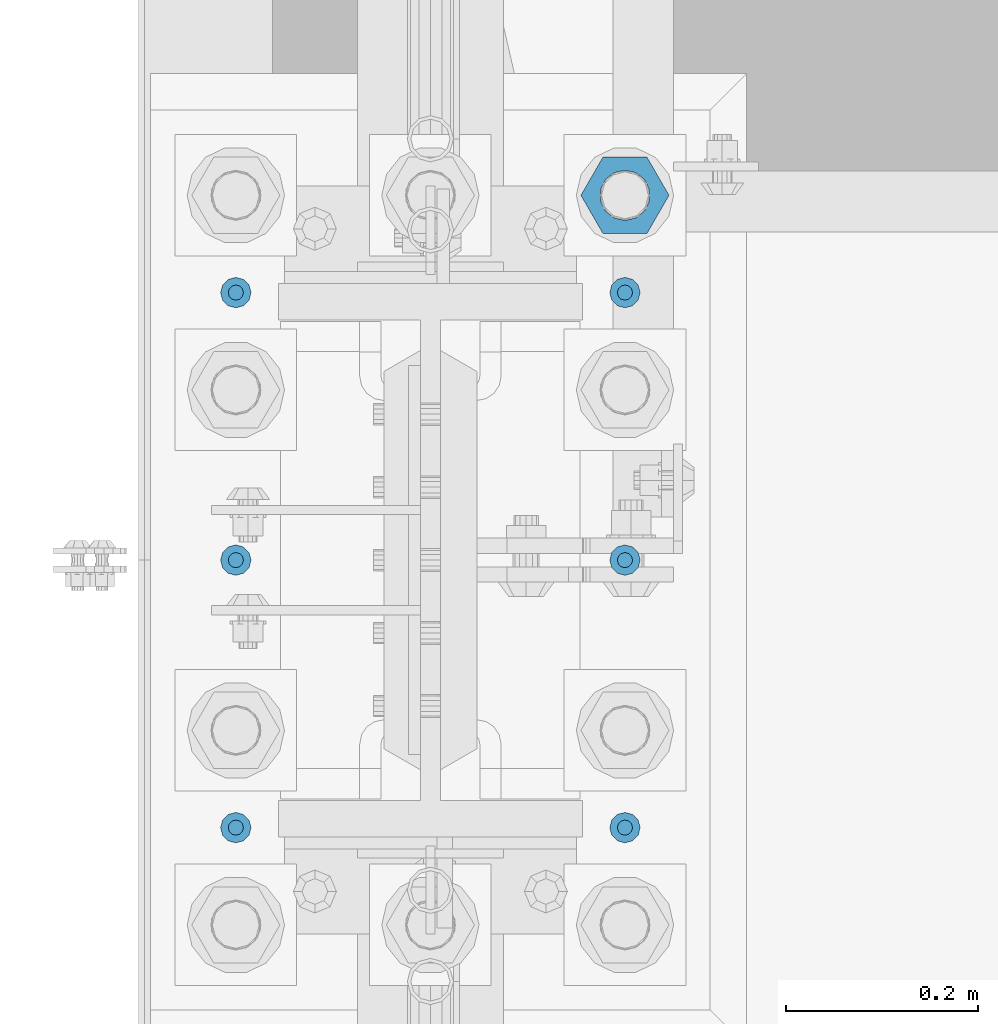
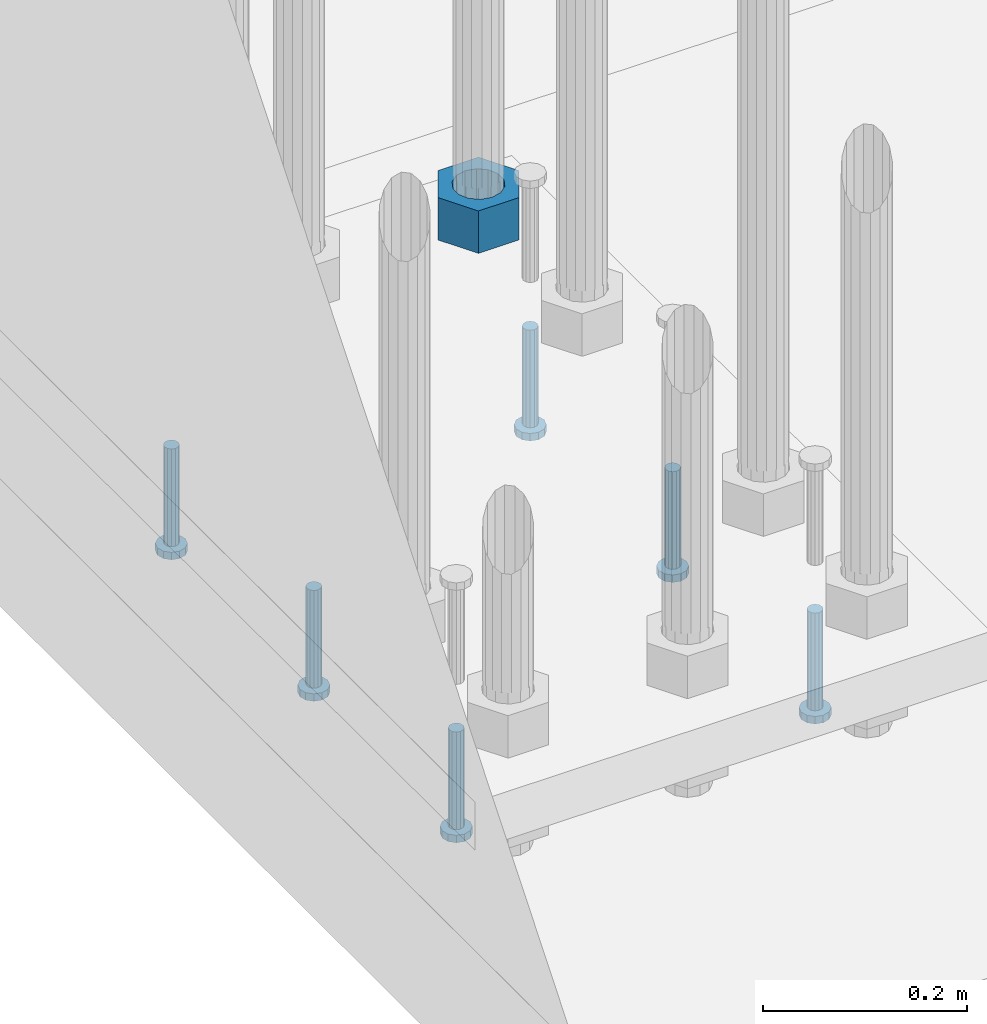
# One storey, part 1238 of 1876: 7 beams, 1 element without a shape of its own.
"""IFC2X3 building model written with IfcOpenShell, lengths in millimetres."""

from ifc_helpers import new_model, si_unit, frame, origin_with_axes, place, context, subcontext, project, spatial, faceted_brep, material, type_object, element, aggregate, save


model = new_model("IFC2X3")

# Units and contexts
model_context = context("Model", 3, precision=1e-05, world=origin_with_axes())
body_context = subcontext(model_context, "Body", "Model", "MODEL_VIEW")
ifc_project = project(units=[si_unit("LENGTHUNIT", "METRE", prefix="MILLI"), si_unit("AREAUNIT", "SQUARE_METRE"), si_unit("VOLUMEUNIT", "CUBIC_METRE"), si_unit("MASSUNIT", "GRAM", prefix="KILO"), si_unit("TIMEUNIT", "SECOND"), si_unit("PLANEANGLEUNIT", "RADIAN"), si_unit("SOLIDANGLEUNIT", "STERADIAN"), si_unit("THERMODYNAMICTEMPERATUREUNIT", "DEGREE_CELSIUS"), si_unit("LUMINOUSINTENSITYUNIT", "LUMEN")], contexts=[model_context])

# Site, building, storey
site_placement = place(None, origin_with_axes())
site = spatial("IfcSite", under=ifc_project, at=site_placement, CompositionType="ELEMENT")
building_placement = place(site_placement, origin_with_axes())
building = spatial("IfcBuilding", under=site, at=building_placement, Name="Undefined", CompositionType="ELEMENT")
storey_placement = place(building_placement, origin_with_axes())
storey = spatial("IfcBuildingStorey", under=building, at=storey_placement, Name="Undefined", CompositionType="ELEMENT", Elevation=0.0)

# Assembly, beams
assembly_placement = place(storey_placement, origin_with_axes())
assembly = element("IfcElementAssembly", 1, at=assembly_placement, inside=storey, Name="TEMPLATE", AssemblyPlace="NOTDEFINED", PredefinedType="RIGID_FRAME")
ifc_material_1 = material(Name="STEEL/A563")
beam_type_1 = type_object("IfcBeamType", Name="2_HEAVY_HEX_NUT", PredefinedType="NOTDEFINED")
beam_1_placement = place(assembly_placement, frame((203.2, 1904.99999847412, -685.799998474121), z_axis=(0.0, 1.0, 0.0), x_axis=(0.0, 0.0, -1.0)))
beam_1 = element("IfcBeam", 2, at=beam_1_placement, type_object=beam_type_1, material=ifc_material_1, Name="NUT", ObjectType="2_HEAVY_HEX_NUT", context=body_context, shape_type="Brep", body=[
    faceted_brep([(0.0, -46.0369987487793, 9.09494701772928e-13), (0.0, -23.0184993743896, -39.869213104248), (50.8, -23.0184993743896, -39.869213104248), (50.8, -46.0369987487793, 9.09494701772928e-13), (0.0, 23.0184993743896, -39.869213104248), (50.8, 23.0184993743896, -39.869213104248), (0.0, 46.0369987487793, -9.09494701772928e-13), (50.8, 46.0369987487793, -9.09494701772928e-13), (0.0, 23.0184993743896, 39.869213104248), (50.8, 23.0184993743896, 39.869213104248), (0.0, -23.0184993743896, 39.869213104248), (50.8, -23.0184993743896, 39.869213104248), (0.0, 0.0, 26.1940002441406), (0.0, 11.3650617044514, 23.5999013092769), (50.8, 11.3650617044513, 23.5999013092771), (50.8, 0.0, 26.1940002441406), (0.0, 20.4791109456437, 16.3316083006703), (50.8, 20.4791109456439, 16.3316083006703), (0.0, 25.5370200498346, 5.82867859874477), (50.8, 25.5370200498343, 5.82867859874455), (0.0, 25.5370200498346, -5.82867859874477), (50.8, 25.5370200498343, -5.82867859874455), (0.0, 20.4791109456437, -16.3316083006703), (50.8, 20.4791109456439, -16.3316083006703), (0.0, 11.3650617044514, -23.5999013092769), (50.8, 11.3650617044514, -23.5999013092771), (0.0, 0.0, -26.1940002441406), (50.8, 0.0, -26.1940002441406), (0.0, -11.3650617044514, -23.5999013092769), (50.8, -11.3650617044513, -23.5999013092771), (0.0, -20.4791109456437, -16.3316083006703), (50.8, -20.4791109456439, -16.3316083006703), (0.0, -25.5370200498346, -5.82867859874477), (50.8, -25.5370200498343, -5.82867859874455), (0.0, -25.5370200498346, 5.82867859874477), (50.8, -25.5370200498343, 5.82867859874455), (0.0, -20.4791109456437, 16.3316083006703), (50.8, -20.4791109456439, 16.3316083006703), (0.0, -11.3650617044514, 23.5999013092769), (50.8, -11.3650617044514, 23.5999013092771)], [[[0, 1, 2, 3]], [[1, 4, 5, 2]], [[4, 6, 7, 5]], [[6, 8, 9, 7]], [[8, 10, 11, 9]], [[10, 0, 3, 11]], [[12, 13, 14, 15]], [[13, 16, 17, 14]], [[16, 18, 19, 17]], [[18, 20, 21, 19]], [[20, 22, 23, 21]], [[22, 24, 25, 23]], [[24, 26, 27, 25]], [[26, 28, 29, 27]], [[28, 30, 31, 29]], [[30, 32, 33, 31]], [[32, 34, 35, 33]], [[34, 36, 37, 35]], [[36, 38, 39, 37]], [[38, 12, 15, 39]], [[5, 7, 9, 11, 3, 2], [17, 19, 21, 23, 25, 27, 29, 31, 33, 35, 37, 39, 15, 14]], [[10, 8, 6, 4, 1, 0], [38, 36, 34, 32, 30, 28, 26, 24, 22, 20, 18, 16, 13, 12]]]),
])
ifc_material_2 = material(Name="STEEL/A108")
beam_type_2 = type_object("IfcBeamType", Name="5/8-DIA_HEADED ANCHOR STUD", PredefinedType="NOTDEFINED")
beam_2_placement = place(assembly_placement, frame((203.2, 1803.4, -793.75), z_axis=(1.0, 0.0, 0.0), x_axis=(0.0, 0.0, -1.0)))
beam_2 = element("IfcBeam", 3, at=beam_2_placement, type_object=beam_type_2, material=ifc_material_2, Name="HEADED ANCHOR STUD", ObjectType="5/8-DIA_HEADED ANCHOR STUD", context=body_context, shape_type="Brep", body=[
    faceted_brep([(0.0, -7.94000005722046, 0.0), (0.0, -6.86999988555908, -3.97000002861023), (116.84, -6.86999988555908, -3.97000002861023), (116.84, -7.94000005722046, 0.0), (0.0, -3.97000002861023, -6.86999988555908), (116.84, -3.97000002861023, -6.86999988555908), (0.0, 0.0, -7.94000005722046), (116.84, 0.0, -7.94000005722046), (0.0, 3.97000002861023, -6.86999988555908), (116.84, 3.97000002861023, -6.86999988555908), (0.0, 6.86999988555908, -3.97000002861023), (116.84, 6.86999988555908, -3.97000002861023), (0.0, 7.94000005722046, 0.0), (116.84, 7.94000005722046, 0.0), (0.0, 6.86999988555908, 3.97000002861023), (116.84, 6.86999988555908, 3.97000002861023), (0.0, 3.97000002861023, 6.86999988555908), (116.84, 3.97000002861023, 6.86999988555908), (0.0, 0.0, 7.94000005722046), (116.84, 0.0, 7.94000005722046), (0.0, -3.97000002861023, 6.86999988555908), (116.84, -3.97000002861023, 6.86999988555908), (0.0, -6.86999988555908, 3.97000002861023), (116.84, -6.86999988555908, 3.97000002861023), (118.11, -13.75, -7.94000005722046), (118.11, -15.8800001144409, 0.0), (118.11, -7.94000005722046, -13.75), (118.11, 0.0, -15.8800001144409), (118.11, 7.94000005722046, -13.75), (118.11, 13.75, -7.94000005722046), (118.11, 15.8800001144409, 0.0), (118.11, 13.75, 7.94000005722046), (118.11, 7.94000005722046, 13.75), (118.11, 0.0, 15.8800001144409), (118.11, -7.94000005722046, 13.75), (118.11, -13.75, 7.94000005722046), (127.0, -13.75, -7.94000005722046), (127.0, -15.8800001144409, 0.0), (127.0, -7.94000005722046, -13.75), (127.0, 0.0, -15.8800001144409), (127.0, 7.94000005722046, -13.75), (127.0, 13.75, -7.94000005722046), (127.0, 15.8800001144409, 0.0), (127.0, 13.75, 7.94000005722046), (127.0, 7.94000005722046, 13.75), (127.0, 0.0, 15.8800001144409), (127.0, -7.94000005722046, 13.75), (127.0, -13.75, 7.94000005722046)], [[[0, 1, 2, 3]], [[1, 4, 5, 2]], [[4, 6, 7, 5]], [[6, 8, 9, 7]], [[8, 10, 11, 9]], [[10, 12, 13, 11]], [[12, 14, 15, 13]], [[14, 16, 17, 15]], [[16, 18, 19, 17]], [[18, 20, 21, 19]], [[20, 22, 23, 21]], [[22, 0, 3, 23]], [[22, 20, 18, 16, 14, 12, 10, 8, 6, 4, 1, 0]], [[3, 2, 24, 25]], [[2, 5, 26, 24]], [[5, 7, 27, 26]], [[7, 9, 28, 27]], [[9, 11, 29, 28]], [[11, 13, 30, 29]], [[13, 15, 31, 30]], [[15, 17, 32, 31]], [[17, 19, 33, 32]], [[19, 21, 34, 33]], [[21, 23, 35, 34]], [[23, 3, 25, 35]], [[25, 24, 36, 37]], [[24, 26, 38, 36]], [[26, 27, 39, 38]], [[27, 28, 40, 39]], [[28, 29, 41, 40]], [[29, 30, 42, 41]], [[30, 31, 43, 42]], [[31, 32, 44, 43]], [[32, 33, 45, 44]], [[33, 34, 46, 45]], [[34, 35, 47, 46]], [[35, 25, 37, 47]], [[38, 39, 40, 41, 42, 43, 44, 45, 46, 47, 37, 36]]]),
])
beam_3_placement = place(assembly_placement, frame((203.2, 1244.6, -793.75), z_axis=(1.0, 0.0, 0.0), x_axis=(0.0, 0.0, -1.0)))
beam_3 = element("IfcBeam", 4, at=beam_3_placement, type_object=beam_type_2, material=ifc_material_2, Name="HEADED ANCHOR STUD", ObjectType="5/8-DIA_HEADED ANCHOR STUD", context=body_context, shape_type="Brep", body=[
    faceted_brep([(0.0, -7.94000005722046, 0.0), (0.0, -6.86999988555908, -3.97000002861023), (116.84, -6.86999988555908, -3.97000002861023), (116.84, -7.94000005722046, 0.0), (0.0, -3.97000002861023, -6.86999988555908), (116.84, -3.97000002861023, -6.86999988555908), (0.0, 0.0, -7.94000005722046), (116.84, 0.0, -7.94000005722046), (0.0, 3.97000002861023, -6.86999988555908), (116.84, 3.97000002861023, -6.86999988555908), (0.0, 6.86999988555908, -3.97000002861023), (116.84, 6.86999988555908, -3.97000002861023), (0.0, 7.94000005722046, 0.0), (116.84, 7.94000005722046, 0.0), (0.0, 6.86999988555908, 3.97000002861023), (116.84, 6.86999988555908, 3.97000002861023), (0.0, 3.97000002861023, 6.86999988555908), (116.84, 3.97000002861023, 6.86999988555908), (0.0, 0.0, 7.94000005722046), (116.84, 0.0, 7.94000005722046), (0.0, -3.97000002861023, 6.86999988555908), (116.84, -3.97000002861023, 6.86999988555908), (0.0, -6.86999988555908, 3.97000002861023), (116.84, -6.86999988555908, 3.97000002861023), (118.11, -13.75, -7.94000005722046), (118.11, -15.8800001144409, 0.0), (118.11, -7.94000005722046, -13.75), (118.11, 0.0, -15.8800001144409), (118.11, 7.94000005722046, -13.75), (118.11, 13.75, -7.94000005722046), (118.11, 15.8800001144409, 0.0), (118.11, 13.75, 7.94000005722046), (118.11, 7.94000005722046, 13.75), (118.11, 0.0, 15.8800001144409), (118.11, -7.94000005722046, 13.75), (118.11, -13.75, 7.94000005722046), (127.0, -13.75, -7.94000005722046), (127.0, -15.8800001144409, 0.0), (127.0, -7.94000005722046, -13.75), (127.0, 0.0, -15.8800001144409), (127.0, 7.94000005722046, -13.75), (127.0, 13.75, -7.94000005722046), (127.0, 15.8800001144409, 0.0), (127.0, 13.75, 7.94000005722046), (127.0, 7.94000005722046, 13.75), (127.0, 0.0, 15.8800001144409), (127.0, -7.94000005722046, 13.75), (127.0, -13.75, 7.94000005722046)], [[[0, 1, 2, 3]], [[1, 4, 5, 2]], [[4, 6, 7, 5]], [[6, 8, 9, 7]], [[8, 10, 11, 9]], [[10, 12, 13, 11]], [[12, 14, 15, 13]], [[14, 16, 17, 15]], [[16, 18, 19, 17]], [[18, 20, 21, 19]], [[20, 22, 23, 21]], [[22, 0, 3, 23]], [[22, 20, 18, 16, 14, 12, 10, 8, 6, 4, 1, 0]], [[3, 2, 24, 25]], [[2, 5, 26, 24]], [[5, 7, 27, 26]], [[7, 9, 28, 27]], [[9, 11, 29, 28]], [[11, 13, 30, 29]], [[13, 15, 31, 30]], [[15, 17, 32, 31]], [[17, 19, 33, 32]], [[19, 21, 34, 33]], [[21, 23, 35, 34]], [[23, 3, 25, 35]], [[25, 24, 36, 37]], [[24, 26, 38, 36]], [[26, 27, 39, 38]], [[27, 28, 40, 39]], [[28, 29, 41, 40]], [[29, 30, 42, 41]], [[30, 31, 43, 42]], [[31, 32, 44, 43]], [[32, 33, 45, 44]], [[33, 34, 46, 45]], [[34, 35, 47, 46]], [[35, 25, 37, 47]], [[38, 39, 40, 41, 42, 43, 44, 45, 46, 47, 37, 36]]]),
])
beam_4_placement = place(assembly_placement, frame((203.2, 1524.0, -793.75), z_axis=(1.0, 0.0, 0.0), x_axis=(0.0, 0.0, -1.0)))
beam_4 = element("IfcBeam", 5, at=beam_4_placement, type_object=beam_type_2, material=ifc_material_2, Name="HEADED ANCHOR STUD", ObjectType="5/8-DIA_HEADED ANCHOR STUD", context=body_context, shape_type="Brep", body=[
    faceted_brep([(0.0, -7.94000005722046, 0.0), (0.0, -6.86999988555908, -3.97000002861023), (116.84, -6.86999988555908, -3.97000002861023), (116.84, -7.94000005722046, 0.0), (0.0, -3.97000002861023, -6.86999988555908), (116.84, -3.97000002861023, -6.86999988555908), (0.0, 0.0, -7.94000005722046), (116.84, 0.0, -7.94000005722046), (0.0, 3.97000002861023, -6.86999988555908), (116.84, 3.97000002861023, -6.86999988555908), (0.0, 6.86999988555908, -3.97000002861023), (116.84, 6.86999988555908, -3.97000002861023), (0.0, 7.94000005722046, 0.0), (116.84, 7.94000005722046, 0.0), (0.0, 6.86999988555908, 3.97000002861023), (116.84, 6.86999988555908, 3.97000002861023), (0.0, 3.97000002861023, 6.86999988555908), (116.84, 3.97000002861023, 6.86999988555908), (0.0, 0.0, 7.94000005722046), (116.84, 0.0, 7.94000005722046), (0.0, -3.97000002861023, 6.86999988555908), (116.84, -3.97000002861023, 6.86999988555908), (0.0, -6.86999988555908, 3.97000002861023), (116.84, -6.86999988555908, 3.97000002861023), (118.11, -13.75, -7.94000005722046), (118.11, -15.8800001144409, 0.0), (118.11, -7.94000005722046, -13.75), (118.11, 0.0, -15.8800001144409), (118.11, 7.94000005722046, -13.75), (118.11, 13.75, -7.94000005722046), (118.11, 15.8800001144409, 0.0), (118.11, 13.75, 7.94000005722046), (118.11, 7.94000005722046, 13.75), (118.11, 0.0, 15.8800001144409), (118.11, -7.94000005722046, 13.75), (118.11, -13.75, 7.94000005722046), (127.0, -13.75, -7.94000005722046), (127.0, -15.8800001144409, 0.0), (127.0, -7.94000005722046, -13.75), (127.0, 0.0, -15.8800001144409), (127.0, 7.94000005722046, -13.75), (127.0, 13.75, -7.94000005722046), (127.0, 15.8800001144409, 0.0), (127.0, 13.75, 7.94000005722046), (127.0, 7.94000005722046, 13.75), (127.0, 0.0, 15.8800001144409), (127.0, -7.94000005722046, 13.75), (127.0, -13.75, 7.94000005722046)], [[[0, 1, 2, 3]], [[1, 4, 5, 2]], [[4, 6, 7, 5]], [[6, 8, 9, 7]], [[8, 10, 11, 9]], [[10, 12, 13, 11]], [[12, 14, 15, 13]], [[14, 16, 17, 15]], [[16, 18, 19, 17]], [[18, 20, 21, 19]], [[20, 22, 23, 21]], [[22, 0, 3, 23]], [[22, 20, 18, 16, 14, 12, 10, 8, 6, 4, 1, 0]], [[3, 2, 24, 25]], [[2, 5, 26, 24]], [[5, 7, 27, 26]], [[7, 9, 28, 27]], [[9, 11, 29, 28]], [[11, 13, 30, 29]], [[13, 15, 31, 30]], [[15, 17, 32, 31]], [[17, 19, 33, 32]], [[19, 21, 34, 33]], [[21, 23, 35, 34]], [[23, 3, 25, 35]], [[25, 24, 36, 37]], [[24, 26, 38, 36]], [[26, 27, 39, 38]], [[27, 28, 40, 39]], [[28, 29, 41, 40]], [[29, 30, 42, 41]], [[30, 31, 43, 42]], [[31, 32, 44, 43]], [[32, 33, 45, 44]], [[33, 34, 46, 45]], [[34, 35, 47, 46]], [[35, 25, 37, 47]], [[38, 39, 40, 41, 42, 43, 44, 45, 46, 47, 37, 36]]]),
])
beam_5_placement = place(assembly_placement, frame((-203.2, 1803.4, -793.75), z_axis=(1.0, 0.0, 0.0), x_axis=(0.0, 0.0, -1.0)))
beam_5 = element("IfcBeam", 6, at=beam_5_placement, type_object=beam_type_2, material=ifc_material_2, Name="HEADED ANCHOR STUD", ObjectType="5/8-DIA_HEADED ANCHOR STUD", context=body_context, shape_type="Brep", body=[
    faceted_brep([(0.0, -7.94000005722046, 0.0), (0.0, -6.86999988555908, -3.97000002861023), (116.84, -6.86999988555908, -3.97000002861023), (116.84, -7.94000005722046, 0.0), (0.0, -3.97000002861023, -6.86999988555908), (116.84, -3.97000002861023, -6.86999988555908), (0.0, 0.0, -7.94000005722046), (116.84, 0.0, -7.94000005722046), (0.0, 3.97000002861023, -6.86999988555908), (116.84, 3.97000002861023, -6.86999988555908), (0.0, 6.86999988555908, -3.97000002861023), (116.84, 6.86999988555908, -3.97000002861023), (0.0, 7.94000005722046, 0.0), (116.84, 7.94000005722046, 0.0), (0.0, 6.86999988555908, 3.97000002861023), (116.84, 6.86999988555908, 3.97000002861023), (0.0, 3.97000002861023, 6.86999988555908), (116.84, 3.97000002861023, 6.86999988555908), (0.0, 0.0, 7.94000005722046), (116.84, 0.0, 7.94000005722046), (0.0, -3.97000002861023, 6.86999988555908), (116.84, -3.97000002861023, 6.86999988555908), (0.0, -6.86999988555908, 3.97000002861023), (116.84, -6.86999988555908, 3.97000002861023), (118.11, -13.75, -7.94000005722046), (118.11, -15.8800001144409, 0.0), (118.11, -7.94000005722046, -13.75), (118.11, 0.0, -15.8800001144409), (118.11, 7.94000005722046, -13.75), (118.11, 13.75, -7.94000005722046), (118.11, 15.8800001144409, 0.0), (118.11, 13.75, 7.94000005722046), (118.11, 7.94000005722046, 13.75), (118.11, 0.0, 15.8800001144409), (118.11, -7.94000005722046, 13.75), (118.11, -13.75, 7.94000005722046), (127.0, -13.75, -7.94000005722046), (127.0, -15.8800001144409, 0.0), (127.0, -7.94000005722046, -13.75), (127.0, 0.0, -15.8800001144409), (127.0, 7.94000005722046, -13.75), (127.0, 13.75, -7.94000005722046), (127.0, 15.8800001144409, 0.0), (127.0, 13.75, 7.94000005722046), (127.0, 7.94000005722046, 13.75), (127.0, 0.0, 15.8800001144409), (127.0, -7.94000005722046, 13.75), (127.0, -13.75, 7.94000005722046)], [[[0, 1, 2, 3]], [[1, 4, 5, 2]], [[4, 6, 7, 5]], [[6, 8, 9, 7]], [[8, 10, 11, 9]], [[10, 12, 13, 11]], [[12, 14, 15, 13]], [[14, 16, 17, 15]], [[16, 18, 19, 17]], [[18, 20, 21, 19]], [[20, 22, 23, 21]], [[22, 0, 3, 23]], [[22, 20, 18, 16, 14, 12, 10, 8, 6, 4, 1, 0]], [[3, 2, 24, 25]], [[2, 5, 26, 24]], [[5, 7, 27, 26]], [[7, 9, 28, 27]], [[9, 11, 29, 28]], [[11, 13, 30, 29]], [[13, 15, 31, 30]], [[15, 17, 32, 31]], [[17, 19, 33, 32]], [[19, 21, 34, 33]], [[21, 23, 35, 34]], [[23, 3, 25, 35]], [[25, 24, 36, 37]], [[24, 26, 38, 36]], [[26, 27, 39, 38]], [[27, 28, 40, 39]], [[28, 29, 41, 40]], [[29, 30, 42, 41]], [[30, 31, 43, 42]], [[31, 32, 44, 43]], [[32, 33, 45, 44]], [[33, 34, 46, 45]], [[34, 35, 47, 46]], [[35, 25, 37, 47]], [[38, 39, 40, 41, 42, 43, 44, 45, 46, 47, 37, 36]]]),
])
beam_6_placement = place(assembly_placement, frame((-203.2, 1244.6, -793.75), z_axis=(1.0, 0.0, 0.0), x_axis=(0.0, 0.0, -1.0)))
beam_6 = element("IfcBeam", 7, at=beam_6_placement, type_object=beam_type_2, material=ifc_material_2, Name="HEADED ANCHOR STUD", ObjectType="5/8-DIA_HEADED ANCHOR STUD", context=body_context, shape_type="Brep", body=[
    faceted_brep([(0.0, -7.94000005722046, 0.0), (0.0, -6.86999988555908, -3.97000002861023), (116.84, -6.86999988555908, -3.97000002861023), (116.84, -7.94000005722046, 0.0), (0.0, -3.97000002861023, -6.86999988555908), (116.84, -3.97000002861023, -6.86999988555908), (0.0, 0.0, -7.94000005722046), (116.84, 0.0, -7.94000005722046), (0.0, 3.97000002861023, -6.86999988555908), (116.84, 3.97000002861023, -6.86999988555908), (0.0, 6.86999988555908, -3.97000002861023), (116.84, 6.86999988555908, -3.97000002861023), (0.0, 7.94000005722046, 0.0), (116.84, 7.94000005722046, 0.0), (0.0, 6.86999988555908, 3.97000002861023), (116.84, 6.86999988555908, 3.97000002861023), (0.0, 3.97000002861023, 6.86999988555908), (116.84, 3.97000002861023, 6.86999988555908), (0.0, 0.0, 7.94000005722046), (116.84, 0.0, 7.94000005722046), (0.0, -3.97000002861023, 6.86999988555908), (116.84, -3.97000002861023, 6.86999988555908), (0.0, -6.86999988555908, 3.97000002861023), (116.84, -6.86999988555908, 3.97000002861023), (118.11, -13.75, -7.94000005722046), (118.11, -15.8800001144409, 0.0), (118.11, -7.94000005722046, -13.75), (118.11, 0.0, -15.8800001144409), (118.11, 7.94000005722046, -13.75), (118.11, 13.75, -7.94000005722046), (118.11, 15.8800001144409, 0.0), (118.11, 13.75, 7.94000005722046), (118.11, 7.94000005722046, 13.75), (118.11, 0.0, 15.8800001144409), (118.11, -7.94000005722046, 13.75), (118.11, -13.75, 7.94000005722046), (127.0, -13.75, -7.94000005722046), (127.0, -15.8800001144409, 0.0), (127.0, -7.94000005722046, -13.75), (127.0, 0.0, -15.8800001144409), (127.0, 7.94000005722046, -13.75), (127.0, 13.75, -7.94000005722046), (127.0, 15.8800001144409, 0.0), (127.0, 13.75, 7.94000005722046), (127.0, 7.94000005722046, 13.75), (127.0, 0.0, 15.8800001144409), (127.0, -7.94000005722046, 13.75), (127.0, -13.75, 7.94000005722046)], [[[0, 1, 2, 3]], [[1, 4, 5, 2]], [[4, 6, 7, 5]], [[6, 8, 9, 7]], [[8, 10, 11, 9]], [[10, 12, 13, 11]], [[12, 14, 15, 13]], [[14, 16, 17, 15]], [[16, 18, 19, 17]], [[18, 20, 21, 19]], [[20, 22, 23, 21]], [[22, 0, 3, 23]], [[22, 20, 18, 16, 14, 12, 10, 8, 6, 4, 1, 0]], [[3, 2, 24, 25]], [[2, 5, 26, 24]], [[5, 7, 27, 26]], [[7, 9, 28, 27]], [[9, 11, 29, 28]], [[11, 13, 30, 29]], [[13, 15, 31, 30]], [[15, 17, 32, 31]], [[17, 19, 33, 32]], [[19, 21, 34, 33]], [[21, 23, 35, 34]], [[23, 3, 25, 35]], [[25, 24, 36, 37]], [[24, 26, 38, 36]], [[26, 27, 39, 38]], [[27, 28, 40, 39]], [[28, 29, 41, 40]], [[29, 30, 42, 41]], [[30, 31, 43, 42]], [[31, 32, 44, 43]], [[32, 33, 45, 44]], [[33, 34, 46, 45]], [[34, 35, 47, 46]], [[35, 25, 37, 47]], [[38, 39, 40, 41, 42, 43, 44, 45, 46, 47, 37, 36]]]),
])
beam_7_placement = place(assembly_placement, frame((-203.2, 1524.0, -793.75), z_axis=(1.0, 0.0, 0.0), x_axis=(0.0, 0.0, -1.0)))
beam_7 = element("IfcBeam", 8, at=beam_7_placement, type_object=beam_type_2, material=ifc_material_2, Name="HEADED ANCHOR STUD", ObjectType="5/8-DIA_HEADED ANCHOR STUD", context=body_context, shape_type="Brep", body=[
    faceted_brep([(0.0, -7.94000005722046, 0.0), (0.0, -6.86999988555908, -3.97000002861023), (116.84, -6.86999988555908, -3.97000002861023), (116.84, -7.94000005722046, 0.0), (0.0, -3.97000002861023, -6.86999988555908), (116.84, -3.97000002861023, -6.86999988555908), (0.0, 0.0, -7.94000005722046), (116.84, 0.0, -7.94000005722046), (0.0, 3.97000002861023, -6.86999988555908), (116.84, 3.97000002861023, -6.86999988555908), (0.0, 6.86999988555908, -3.97000002861023), (116.84, 6.86999988555908, -3.97000002861023), (0.0, 7.94000005722046, 0.0), (116.84, 7.94000005722046, 0.0), (0.0, 6.86999988555908, 3.97000002861023), (116.84, 6.86999988555908, 3.97000002861023), (0.0, 3.97000002861023, 6.86999988555908), (116.84, 3.97000002861023, 6.86999988555908), (0.0, 0.0, 7.94000005722046), (116.84, 0.0, 7.94000005722046), (0.0, -3.97000002861023, 6.86999988555908), (116.84, -3.97000002861023, 6.86999988555908), (0.0, -6.86999988555908, 3.97000002861023), (116.84, -6.86999988555908, 3.97000002861023), (118.11, -13.75, -7.94000005722046), (118.11, -15.8800001144409, 0.0), (118.11, -7.94000005722046, -13.75), (118.11, 0.0, -15.8800001144409), (118.11, 7.94000005722046, -13.75), (118.11, 13.75, -7.94000005722046), (118.11, 15.8800001144409, 0.0), (118.11, 13.75, 7.94000005722046), (118.11, 7.94000005722046, 13.75), (118.11, 0.0, 15.8800001144409), (118.11, -7.94000005722046, 13.75), (118.11, -13.75, 7.94000005722046), (127.0, -13.75, -7.94000005722046), (127.0, -15.8800001144409, 0.0), (127.0, -7.94000005722046, -13.75), (127.0, 0.0, -15.8800001144409), (127.0, 7.94000005722046, -13.75), (127.0, 13.75, -7.94000005722046), (127.0, 15.8800001144409, 0.0), (127.0, 13.75, 7.94000005722046), (127.0, 7.94000005722046, 13.75), (127.0, 0.0, 15.8800001144409), (127.0, -7.94000005722046, 13.75), (127.0, -13.75, 7.94000005722046)], [[[0, 1, 2, 3]], [[1, 4, 5, 2]], [[4, 6, 7, 5]], [[6, 8, 9, 7]], [[8, 10, 11, 9]], [[10, 12, 13, 11]], [[12, 14, 15, 13]], [[14, 16, 17, 15]], [[16, 18, 19, 17]], [[18, 20, 21, 19]], [[20, 22, 23, 21]], [[22, 0, 3, 23]], [[22, 20, 18, 16, 14, 12, 10, 8, 6, 4, 1, 0]], [[3, 2, 24, 25]], [[2, 5, 26, 24]], [[5, 7, 27, 26]], [[7, 9, 28, 27]], [[9, 11, 29, 28]], [[11, 13, 30, 29]], [[13, 15, 31, 30]], [[15, 17, 32, 31]], [[17, 19, 33, 32]], [[19, 21, 34, 33]], [[21, 23, 35, 34]], [[23, 3, 25, 35]], [[25, 24, 36, 37]], [[24, 26, 38, 36]], [[26, 27, 39, 38]], [[27, 28, 40, 39]], [[28, 29, 41, 40]], [[29, 30, 42, 41]], [[30, 31, 43, 42]], [[31, 32, 44, 43]], [[32, 33, 45, 44]], [[33, 34, 46, 45]], [[34, 35, 47, 46]], [[35, 25, 37, 47]], [[38, 39, 40, 41, 42, 43, 44, 45, 46, 47, 37, 36]]]),
])
aggregate(assembly, [beam_1, beam_2, beam_3, beam_4, beam_5, beam_6, beam_7])

save(model, "model.ifc")
